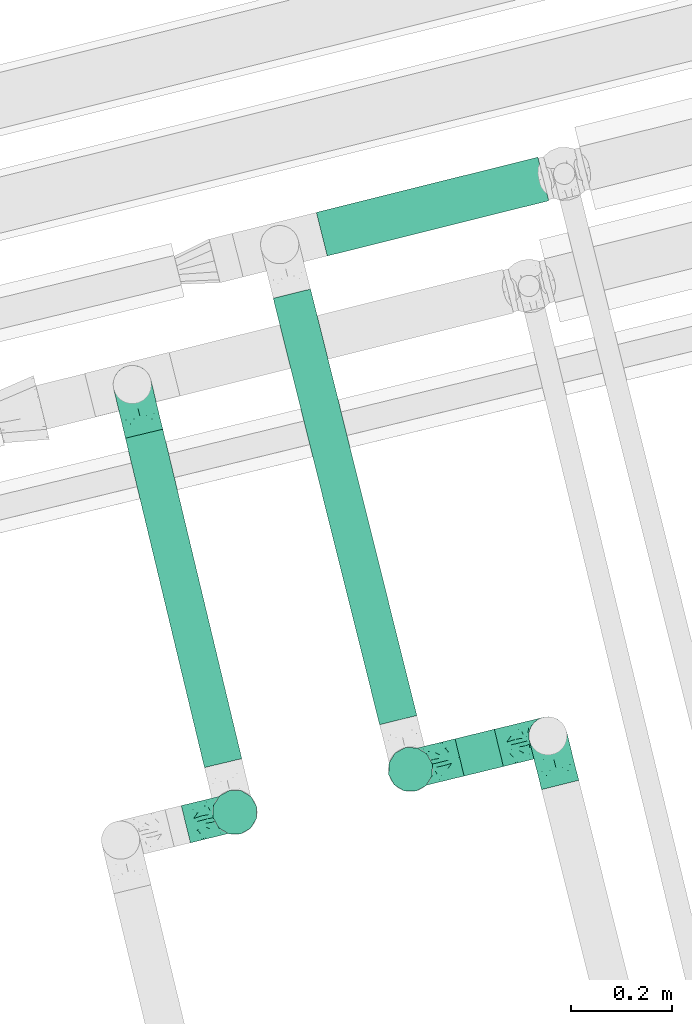
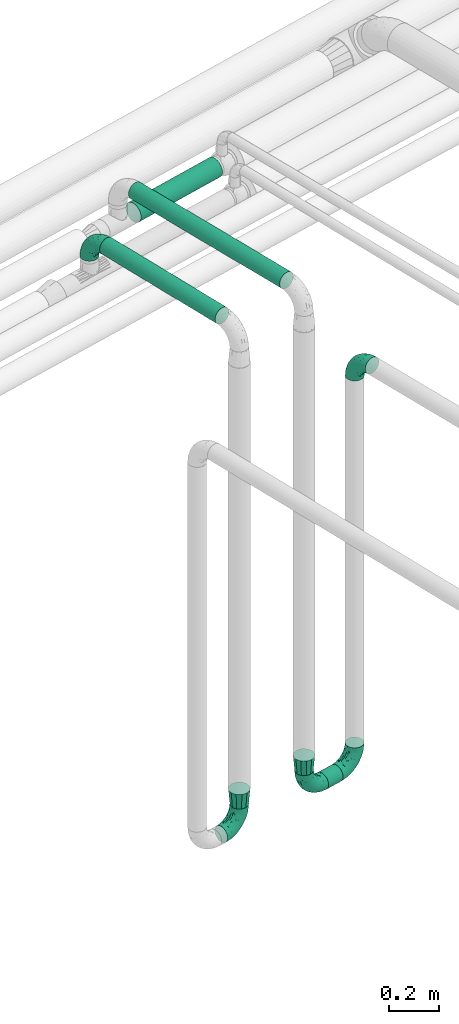
# One storey, part 52 of 93: 7 flow fittings, 4 flow segments.
"""IFC2X3 building model written with IfcOpenShell, lengths in millimetres."""

from ifc_helpers import new_model, entity, si_unit, converted_unit, derived_unit, direction, frame, origin, origin_2d_with_axis, place, context, subcontext, project, spatial, circle, extrude, faceted_brep, source, transform, mapped, material, type_object, type_shapes, element, save


model = new_model("IFC2X3")

# Units and contexts
model_context = context("Model", 3, precision=0.01, world=origin(), true_north=direction((6.12303176911189e-17, 1.0)))
body_context = subcontext(model_context, "Body", "Model", "MODEL_VIEW")
ifc_project = project(units=[si_unit("LENGTHUNIT", "METRE", prefix="MILLI"), si_unit("AREAUNIT", "SQUARE_METRE"), si_unit("VOLUMEUNIT", "CUBIC_METRE"), converted_unit("PLANEANGLEUNIT", "DEGREE", entity("IfcRatioMeasure", 0.0174532925199433), si_unit("PLANEANGLEUNIT", "RADIAN"), dimensions=[0, 0, 0, 0, 0, 0, 0]), si_unit("MASSUNIT", "GRAM", prefix="KILO"), derived_unit("MASSDENSITYUNIT", [(si_unit("MASSUNIT", "GRAM", prefix="KILO"), 1), (si_unit("LENGTHUNIT", "METRE"), -3)]), derived_unit("MOMENTOFINERTIAUNIT", [(si_unit("LENGTHUNIT", "METRE"), 4)]), si_unit("TIMEUNIT", "SECOND"), si_unit("FREQUENCYUNIT", "HERTZ"), si_unit("THERMODYNAMICTEMPERATUREUNIT", "DEGREE_CELSIUS"), derived_unit("THERMALTRANSMITTANCEUNIT", [(si_unit("MASSUNIT", "GRAM", prefix="KILO"), 1), (si_unit("THERMODYNAMICTEMPERATUREUNIT", "KELVIN"), -1), (si_unit("TIMEUNIT", "SECOND"), -3)]), derived_unit("VOLUMETRICFLOWRATEUNIT", [(si_unit("LENGTHUNIT", "METRE"), 3), (si_unit("TIMEUNIT", "SECOND"), -1)]), derived_unit("MASSFLOWRATEUNIT", [(si_unit("MASSUNIT", "GRAM", prefix="KILO"), 1), (si_unit("TIMEUNIT", "SECOND"), -1)]), derived_unit("ROTATIONALFREQUENCYUNIT", [(si_unit("TIMEUNIT", "SECOND"), -1)]), si_unit("ELECTRICCURRENTUNIT", "AMPERE"), si_unit("ELECTRICVOLTAGEUNIT", "VOLT"), si_unit("POWERUNIT", "WATT"), si_unit("FORCEUNIT", "NEWTON", prefix="KILO"), si_unit("ILLUMINANCEUNIT", "LUX"), si_unit("LUMINOUSFLUXUNIT", "LUMEN"), si_unit("LUMINOUSINTENSITYUNIT", "CANDELA"), derived_unit("USERDEFINED", [(si_unit("MASSUNIT", "GRAM", prefix="KILO"), -1), (si_unit("LENGTHUNIT", "METRE"), -2), (si_unit("TIMEUNIT", "SECOND"), 3), (si_unit("LUMINOUSFLUXUNIT", "LUMEN"), 1)]), derived_unit("LINEARVELOCITYUNIT", [(si_unit("LENGTHUNIT", "METRE"), 1), (si_unit("TIMEUNIT", "SECOND"), -1)]), si_unit("PRESSUREUNIT", "PASCAL"), derived_unit("USERDEFINED", [(si_unit("LENGTHUNIT", "METRE"), -2), (si_unit("MASSUNIT", "GRAM", prefix="KILO"), 1), (si_unit("TIMEUNIT", "SECOND"), -2)]), derived_unit("LINEARFORCEUNIT", [(si_unit("MASSUNIT", "GRAM", prefix="KILO"), 1), (si_unit("LENGTHUNIT", "METRE"), 1), (si_unit("TIMEUNIT", "SECOND"), -2), (si_unit("LENGTHUNIT", "METRE"), -1)]), derived_unit("PLANARFORCEUNIT", [(si_unit("MASSUNIT", "GRAM", prefix="KILO"), 1), (si_unit("LENGTHUNIT", "METRE"), 1), (si_unit("TIMEUNIT", "SECOND"), -2), (si_unit("LENGTHUNIT", "METRE"), -2)])], contexts=[model_context])

# Site, building, storey
site_placement = place(None, origin())
site = spatial("IfcSite", under=ifc_project, at=site_placement, CompositionType="ELEMENT")
building_placement = place(site_placement, origin())
building = spatial("IfcBuilding", under=site, at=building_placement, CompositionType="ELEMENT")
storey_placement = place(building_placement, frame((0.0, 0.0, -4200.0)))
storey = spatial("IfcBuildingStorey", under=building, at=storey_placement, CompositionType="ELEMENT", Elevation=-4200.0)

# Flow segments
pipe_segment_type = type_object("IfcPipeSegmentType", PredefinedType="NOTDEFINED")
flow_segment_1_placement = place(storey_placement, frame((-11643.94, 11578.44, 2660.4)))
element("IfcFlowSegment", 1, at=flow_segment_1_placement, inside=storey, type_object=pipe_segment_type, context=body_context, shape_type="SweptSolid", body=[
    extrude(circle(Radius=38.0, at=origin_2d_with_axis()), frame((38.55, 662.55, 39.6), z_axis=(0.233250782190029, -0.972416614732461, 0.0), x_axis=(-0.972416614732461, -0.233250782190029, 2.36724192397386e-08)), (0.0, 0.0, 1.0), 670.590915200018),
])
flow_segment_2_placement = place(storey_placement, frame((-11351.29, 11663.21, 2660.4)))
element("IfcFlowSegment", 2, at=flow_segment_2_placement, inside=storey, type_object=pipe_segment_type, context=body_context, shape_type="SweptSolid", body=[
    extrude(circle(Radius=38.0, at=origin_2d_with_axis()), frame((248.96, 10.79, 39.6), z_axis=(-0.241950055468514, 0.970288704798105, 0.0), x_axis=(0.970288704798104, 0.241950055468514, 1.38775757780529e-08)), (0.0, 0.0, 1.0), 869.994640308663),
])
flow_segment_3_placement = place(storey_placement, frame((-10991.44, 11561.61, 220.4)))
element("IfcFlowSegment", 3, at=flow_segment_3_placement, inside=storey, type_object=pipe_segment_type, context=body_context, shape_type="SweptSolid", body=[
    extrude(circle(Radius=38.0, at=origin_2d_with_axis()), frame((10.59, 38.51, 39.6), z_axis=(0.97155336378743, 0.236820736662418, 0.0), x_axis=(0.236820736662418, -0.97155336378743, 0.0)), (0.0, 0.0, 1.0), 80.0000000000123),
])
flow_segment_4_placement = place(storey_placement, frame((-11265.94, 12591.21, 2454.21)))
element("IfcFlowSegment", 4, at=flow_segment_4_placement, inside=storey, type_object=pipe_segment_type, context=body_context, shape_type="SweptSolid", body=[
    extrude(circle(Radius=44.5, at=origin_2d_with_axis()), frame((12.36, 44.77, 46.1), z_axis=(0.970294477586808, 0.241926903763397, 0.0), x_axis=(-0.241926903763397, 0.970294477586808, 0.0)), (0.0, 0.0, 1.0), 451.870706498896),
])

# Flow fittings
ifc_material = material()
pipe_fitting_type_1 = type_object("IfcPipeFittingType", Name="ADSK_2", PredefinedType="NOTDEFINED", material=ifc_material)
shared_shape_1 = source(origin(), body_context, "Body", "Brep", [
    faceted_brep([(-100.0, 19.0, -32.91), (-100.0, 9.84, -36.71), (-100.0, 0.0, -38.0), (-100.0, -9.84, -36.71), (-100.0, -19.0, -32.91), (-100.0, -26.87, -26.87), (-100.0, -32.91, -19.0), (-100.0, -36.71, -9.84), (-100.0, -38.0, 0.0), (-100.0, -36.71, 9.84), (-100.0, -32.91, 19.0), (-100.0, -26.87, 26.87), (-100.0, -19.0, 32.91), (-100.0, -9.84, 36.71), (-100.0, 0.0, 38.0), (-100.0, 9.84, 36.71), (-100.0, 19.0, 32.91), (-100.0, 26.87, 26.87), (-100.0, 32.91, 19.0), (-100.0, 36.71, 9.84), (-100.0, 38.0, 0.0), (-100.0, 36.71, -9.84), (-100.0, 32.91, -19.0), (-100.0, 26.87, -26.87), (0.0, 100.0, -38.0), (-9.84, 100.0, -36.71), (-19.0, 100.0, -32.91), (-26.87, 100.0, -26.87), (-32.91, 100.0, -19.0), (-36.71, 100.0, -9.84), (-38.0, 100.0, 0.0), (-36.71, 100.0, 9.84), (-32.91, 100.0, 19.0), (-26.87, 100.0, 26.87), (-19.0, 100.0, 32.91), (-9.84, 100.0, 36.71), (0.0, 100.0, 38.0), (9.84, 100.0, 36.71), (19.0, 100.0, 32.91), (26.87, 100.0, 26.87), (32.91, 100.0, 19.0), (36.71, 100.0, 9.84), (38.0, 100.0, 0.0), (36.71, 100.0, -9.84), (32.91, 100.0, -19.0), (26.87, 100.0, -26.87), (19.0, 100.0, -32.91), (9.84, 100.0, -36.71), (-40.69, 71.44, 16.62), (-81.22, -35.53, 0.0), (-67.52, -31.95, 12.5), (-8.97, -2.95, 6.59), (-11.71, -2.76, 13.62), (-24.68, -14.61, 8.04), (-64.28, -33.3, 0.0), (-83.72, 23.85, 30.89), (-76.19, 33.07, 24.6), (-74.13, -28.58, 21.76), (13.92, 43.47, 26.56), (5.03, 42.28, 32.41), (2.17, 22.78, 25.61), (20.11, 65.77, 28.71), (-65.77, -20.11, 28.71), (-74.23, -13.22, 34.41), (-44.44, -24.14, 12.16), (-47.64, -26.4, 0.0), (-31.0, -19.51, 0.0), (-54.86, 48.59, 21.12), (-81.56, 37.18, 15.86), (-42.28, -5.03, 32.41), (-52.67, 2.67, 37.1), (-14.76, 85.65, 35.5), (-6.46, 75.04, 37.87), (-58.38, 40.19, 26.6), (-15.88, 37.27, 37.68), (-29.21, 13.39, 36.1), (-10.53, 30.95, 35.7), (-77.78, -4.12, 37.45), (-2.67, 52.67, 37.1), (-76.41, 41.64, 8.45), (-71.15, 7.29, 37.89), (-32.26, 79.13, 24.41), (-44.28, 53.84, 26.08), (-25.18, 76.9, 31.2), (19.6, 43.38, 19.97), (6.25, 18.29, 16.9), (19.92, 34.73, 10.46), (-60.8, 50.97, 7.63), (-76.27, 42.72, 0.0), (-77.34, 15.98, 35.72), (-15.11, 15.11, 32.27), (-22.78, -2.17, 25.61), (28.58, 74.13, 21.76), (31.95, 67.52, 12.5), (-51.02, 30.39, 34.96), (-54.69, 20.06, 37.12), (26.4, 47.64, 0.0), (-51.15, 12.85, 38.0), (-32.84, 22.95, 37.94), (4.12, 77.78, 37.45), (-43.38, -19.6, 19.97), (35.53, 81.22, 0.0), (13.22, 74.23, 34.41), (-39.82, 82.33, 7.34), (-42.72, 76.27, 0.0), (-33.83, 52.47, 33.18), (-48.09, 40.81, 31.48), (-56.16, 56.16, 0.0), (-48.2, 64.18, 8.55), (-18.69, 66.93, 35.98), (-49.98, 57.58, 16.12), (-62.54, 46.99, 14.59), (-43.26, -12.84, 27.42), (-17.52, 48.72, 37.89), (-64.19, 29.4, 31.78), (-27.05, 50.9, 36.03), (-36.14, 36.14, 36.75), (-23.99, -8.71, 19.44), (6.3, 13.34, 7.98), (19.51, 31.0, 0.0), (-7.64, 6.3, 21.15), (-16.71, -8.55, 0.0), (33.3, 64.28, 0.0), (-2.42, 2.42, 0.0), (8.55, 16.71, 0.0), (-85.65, 14.76, -35.5), (-23.85, 83.72, -30.89), (-33.07, 76.19, -24.6), (-75.04, 6.46, -37.87), (-37.27, 15.88, -37.68), (-13.39, 29.21, -36.1), (-30.95, 10.53, -35.7), (-79.13, 32.26, -24.41), (-76.9, 25.18, -31.2), (6.3, 13.34, -7.98), (-11.71, -2.76, -13.62), (6.25, 18.29, -16.9), (-82.33, 39.82, -7.34), (-66.93, 18.69, -35.98), (-48.72, 17.52, -37.89), (-64.18, 48.2, -8.55), (31.95, 67.52, -12.5), (28.58, 74.13, -21.76), (-52.47, 33.83, -33.18), (4.12, 77.78, -37.45), (-7.29, 71.15, -37.89), (-15.98, 77.34, -35.72), (-67.52, -31.95, -12.5), (-30.39, 51.02, -34.96), (-20.06, 54.69, -37.12), (-48.59, 54.86, -21.12), (-37.18, 81.56, -15.86), (-74.13, -28.58, -21.76), (-29.4, 64.19, -31.78), (-40.81, 48.09, -31.48), (-40.19, 58.38, -26.6), (-65.77, -20.11, -28.71), (-74.23, -13.22, -34.41), (-39.81, -22.62, -10.22), (-77.78, -4.12, -37.45), (-43.38, -19.6, -19.97), (-12.85, 51.15, -38.0), (-22.95, 32.84, -37.94), (-71.44, 40.69, -16.62), (19.6, 43.38, -19.97), (20.11, 65.77, -28.71), (-52.67, 2.67, -37.1), (-53.84, 44.28, -26.08), (-41.64, 76.41, -8.45), (-23.99, -8.71, -19.44), (-43.47, -13.92, -26.56), (-22.78, -2.17, -25.61), (-20.59, -12.11, -6.83), (13.22, 74.23, -34.41), (5.03, 42.28, -32.41), (-2.67, 52.67, -37.1), (19.92, 34.73, -10.46), (-42.28, -5.03, -32.41), (12.84, 43.26, -27.42), (-50.97, 60.8, -7.63), (-57.58, 49.98, -16.12), (-46.99, 62.54, -14.59), (-50.9, 27.05, -36.03), (-36.14, 36.14, -36.75), (-15.11, 15.11, -32.27), (2.17, 22.78, -25.61), (-7.64, 6.3, -21.15), (-6.28, -0.33, -7.3)], [[[0, 1, 2, 3, 4, 5, 6, 7, 8, 9, 10, 11, 12, 13, 14, 15, 16, 17, 18, 19, 20, 21, 22, 23]], [[24, 25, 26, 27, 28, 29, 30, 31, 32, 33, 34, 35, 36, 37, 38, 39, 40, 41, 42, 43, 44, 45, 46, 47]], [[32, 31, 48]], [[49, 50, 9]], [[51, 52, 53]], [[9, 50, 10]], [[54, 50, 49]], [[17, 55, 56]], [[11, 10, 57]], [[58, 59, 60]], [[61, 39, 38]], [[62, 12, 11]], [[62, 63, 12]], [[64, 65, 66]], [[56, 67, 68]], [[63, 69, 70]], [[35, 71, 72]], [[67, 56, 73]], [[74, 75, 76]], [[16, 55, 17]], [[13, 77, 14]], [[76, 78, 74]], [[68, 79, 19]], [[18, 17, 56]], [[14, 77, 80]], [[20, 19, 79]], [[81, 82, 83]], [[84, 85, 86]], [[87, 88, 79]], [[18, 68, 19]], [[15, 89, 16]], [[14, 80, 15]], [[85, 84, 60]], [[90, 69, 91]], [[92, 84, 93]], [[94, 89, 95]], [[86, 96, 93]], [[83, 71, 34]], [[95, 97, 98]], [[37, 36, 99]], [[40, 39, 92]], [[40, 93, 41]], [[66, 53, 64]], [[92, 93, 40]], [[57, 100, 62]], [[93, 101, 41]], [[93, 84, 86]], [[61, 102, 59]], [[34, 33, 83]], [[103, 48, 31]], [[50, 57, 10]], [[104, 103, 30]], [[94, 105, 106]], [[104, 107, 108]], [[12, 63, 13]], [[83, 109, 71]], [[83, 105, 109]], [[33, 81, 83]], [[67, 110, 111]], [[108, 103, 104]], [[112, 69, 62]], [[34, 71, 35]], [[36, 35, 72]], [[109, 113, 72]], [[102, 38, 37]], [[102, 61, 38]], [[114, 106, 73]], [[89, 15, 80]], [[33, 32, 81]], [[115, 105, 116]], [[109, 115, 113]], [[99, 72, 78]], [[111, 87, 79]], [[108, 87, 110]], [[69, 63, 62]], [[77, 63, 70]], [[100, 117, 112]], [[69, 90, 75]], [[99, 102, 37]], [[78, 76, 59]], [[78, 59, 102]], [[59, 90, 60]], [[100, 57, 50]], [[62, 11, 57]], [[39, 61, 92]], [[84, 92, 61]], [[95, 89, 80]], [[55, 89, 114]], [[83, 82, 105]], [[94, 106, 114]], [[98, 113, 116]], [[78, 72, 113]], [[98, 116, 95]], [[98, 70, 75]], [[32, 48, 81]], [[82, 81, 48]], [[91, 112, 117]], [[60, 84, 58]], [[113, 115, 116]], [[118, 119, 86]], [[90, 91, 60]], [[91, 117, 120]], [[72, 99, 36]], [[102, 99, 78]], [[63, 77, 13]], [[80, 77, 70]], [[95, 80, 97]], [[94, 95, 116]], [[56, 68, 18]], [[79, 68, 111]], [[110, 87, 111]], [[79, 88, 20]], [[108, 107, 87]], [[88, 87, 107]], [[120, 60, 91]], [[66, 121, 53]], [[118, 86, 85]], [[122, 93, 96]], [[52, 118, 85]], [[118, 123, 124, 119]], [[48, 103, 108]], [[30, 103, 31]], [[89, 55, 16]], [[56, 55, 114]], [[80, 70, 97]], [[70, 98, 97]], [[105, 94, 116]], [[89, 94, 114]], [[105, 82, 106]], [[73, 106, 82]], [[67, 73, 82]], [[114, 73, 56]], [[110, 82, 48]], [[67, 111, 68]], [[82, 110, 67]], [[108, 110, 48]], [[69, 75, 70]], [[76, 75, 90]], [[59, 76, 90]], [[78, 113, 74]], [[113, 98, 74]], [[75, 74, 98]], [[9, 8, 49]], [[101, 93, 122]], [[101, 42, 41]], [[72, 71, 109]], [[50, 54, 65]], [[117, 53, 52]], [[109, 105, 115]], [[100, 112, 62]], [[91, 69, 112]], [[123, 51, 121]], [[120, 52, 85]], [[52, 120, 117]], [[60, 120, 85]], [[51, 118, 52]], [[100, 64, 117]], [[50, 64, 100]], [[121, 51, 53]], [[118, 51, 123]], [[84, 61, 58]], [[59, 58, 61]], [[86, 119, 96]], [[65, 64, 50]], [[117, 64, 53]], [[125, 1, 0]], [[27, 126, 127]], [[2, 1, 128]], [[129, 130, 131]], [[132, 133, 23]], [[134, 135, 136]], [[88, 137, 20]], [[138, 139, 128]], [[88, 107, 140]], [[141, 142, 44]], [[138, 133, 143]], [[24, 144, 145]], [[146, 25, 145]], [[125, 133, 138]], [[6, 147, 7]], [[148, 146, 149]], [[147, 49, 7]], [[127, 150, 151]], [[147, 6, 152]], [[153, 154, 155]], [[156, 4, 157]], [[140, 137, 88]], [[24, 145, 25]], [[43, 42, 101]], [[65, 147, 158]], [[148, 143, 154]], [[159, 3, 2]], [[147, 152, 160]], [[149, 161, 162]], [[156, 5, 4]], [[137, 163, 21]], [[142, 164, 165]], [[131, 166, 129]], [[28, 151, 29]], [[167, 133, 132]], [[168, 30, 29]], [[169, 170, 171]], [[127, 28, 27]], [[150, 127, 155]], [[135, 172, 158]], [[26, 25, 146]], [[1, 125, 128]], [[22, 21, 163]], [[126, 27, 26]], [[151, 168, 29]], [[24, 47, 144]], [[45, 165, 46]], [[0, 23, 133]], [[173, 174, 175]], [[119, 134, 176]], [[142, 45, 44]], [[173, 46, 165]], [[141, 44, 43]], [[46, 173, 47]], [[141, 101, 122]], [[156, 157, 177]], [[157, 4, 3]], [[101, 141, 43]], [[178, 174, 165]], [[169, 160, 170]], [[6, 5, 152]], [[170, 177, 171]], [[158, 147, 160]], [[104, 168, 179]], [[141, 96, 176]], [[150, 180, 181]], [[23, 22, 132]], [[182, 143, 183]], [[138, 182, 139]], [[159, 128, 166]], [[181, 179, 168]], [[140, 179, 180]], [[159, 157, 3]], [[166, 131, 177]], [[166, 177, 157]], [[177, 184, 171]], [[174, 173, 165]], [[144, 173, 175]], [[178, 164, 185]], [[174, 184, 130]], [[5, 156, 152]], [[160, 152, 156]], [[164, 142, 141]], [[165, 45, 142]], [[149, 146, 145]], [[126, 146, 153]], [[133, 167, 143]], [[148, 154, 153]], [[162, 139, 183]], [[166, 128, 139]], [[162, 183, 149]], [[162, 175, 130]], [[22, 163, 132]], [[167, 132, 163]], [[174, 185, 184]], [[136, 176, 134]], [[185, 136, 186]], [[158, 172, 66]], [[136, 185, 164]], [[171, 184, 185]], [[128, 159, 2]], [[157, 159, 166]], [[173, 144, 47]], [[145, 144, 175]], [[149, 145, 161]], [[148, 149, 183]], [[127, 151, 28]], [[168, 151, 181]], [[180, 179, 181]], [[168, 104, 30]], [[140, 107, 179]], [[104, 179, 107]], [[176, 136, 164]], [[135, 169, 186]], [[141, 176, 164]], [[134, 119, 124, 123]], [[158, 66, 65]], [[187, 172, 135]], [[163, 137, 140]], [[20, 137, 21]], [[146, 126, 26]], [[127, 126, 153]], [[145, 175, 161]], [[175, 162, 161]], [[143, 148, 183]], [[146, 148, 153]], [[143, 167, 154]], [[155, 154, 167]], [[150, 155, 167]], [[153, 155, 127]], [[180, 167, 163]], [[150, 181, 151]], [[167, 180, 150]], [[140, 180, 163]], [[174, 130, 175]], [[131, 130, 184]], [[177, 131, 184]], [[166, 139, 129]], [[139, 162, 129]], [[130, 129, 162]], [[49, 147, 54]], [[49, 8, 7]], [[133, 125, 0]], [[128, 125, 138]], [[158, 160, 169]], [[65, 54, 147]], [[187, 135, 134]], [[187, 121, 172]], [[134, 123, 187]], [[139, 182, 183]], [[121, 187, 123]], [[121, 66, 172]], [[138, 143, 182]], [[160, 156, 170]], [[177, 170, 156]], [[186, 169, 171]], [[158, 169, 135]], [[185, 186, 171]], [[135, 186, 136]], [[164, 178, 165]], [[185, 174, 178]], [[96, 141, 122]], [[96, 119, 176]]]),
])
type_shapes(pipe_fitting_type_1, [shared_shape_1])
for number, where, z_axis, x_axis, name in (
    (5, (-11425.65, 11491.65, 270.0), (-0.23682073666241, 0.971553363787432, 0.0), (0.0, 0.0, -1.0), "ADSK_2"),
    (6, (-11078.01, 11576.44, 260.0), (0.236820736662414, -0.971553363787431, 0.0), (0.0, 0.0, -1.0), "ADSK_2"),
    (7, (-10805.97, 11642.75, 260.0), (0.236820736662404, -0.971553363787433, 0.0), (0.971553363787433, 0.236820736662404, 0.0), "ADSK_2"),
    (8, (-10805.97, 11642.75, 2250.0), (0.970245218594306, 0.242124380835321, 0.0), (0.0, 0.0, 1.0), "ADSK_2"),
):
    element("IfcFlowFitting", number, at=place(storey_placement, frame(where, z_axis=z_axis, x_axis=x_axis)), inside=storey, type_object=pipe_fitting_type_1, material=ifc_material, Name=name, ObjectType="ADSK_2", context=body_context, shape_type="MappedRepresentation", body=[
        mapped(shared_shape_1, transform((0.0, 0.0, 0.0), scale=1.0)),
    ])
pipe_fitting_type_2 = type_object("IfcPipeFittingType", Name="ADSK_2", PredefinedType="NOTDEFINED", material=ifc_material)
shared_shape_2 = source(origin(), body_context, "Body", "Brep", [
    faceted_brep([(75.0, -44.5, 0.0), (75.0, -41.54, -11.05), (75.0, -38.54, -22.25), (75.0, -30.39, -30.39), (75.0, -22.25, -38.54), (75.0, -11.13, -41.52), (75.0, 0.0, -44.5), (75.0, 11.12, -41.52), (75.0, 22.25, -38.54), (75.0, 30.39, -30.39), (75.0, 38.54, -22.25), (75.0, 41.54, -11.05), (75.0, 44.5, 0.0), (75.0, 41.54, 11.05), (75.0, 38.54, 22.25), (75.0, 30.39, 30.39), (75.0, 22.25, 38.54), (75.0, 11.12, 41.52), (75.0, 0.0, 44.5), (75.0, -11.13, 41.52), (75.0, -22.25, 38.54), (75.0, -30.39, 30.39), (75.0, -38.54, 22.25), (75.0, -41.54, 11.05), (0.0, -32.91, -19.0), (0.0, -35.45, -9.5), (0.0, -38.0, 0.0), (0.0, -35.45, 9.5), (0.0, -32.91, 19.0), (0.0, -25.95, 25.95), (0.0, -19.0, 32.91), (0.0, -9.5, 35.45), (0.0, 0.0, 38.0), (0.0, 9.5, 35.45), (0.0, 19.0, 32.91), (0.0, 25.95, 25.95), (0.0, 32.91, 19.0), (0.0, 35.45, 9.5), (0.0, 38.0, 0.0), (0.0, 35.45, -9.5), (0.0, 32.91, -19.0), (0.0, 25.95, -25.95), (0.0, 19.0, -32.91), (0.0, 9.5, -35.45), (0.0, 0.0, -38.0), (0.0, -9.5, -35.45), (0.0, -19.0, -32.91), (0.0, -25.95, -25.95)], [[[0, 1, 2, 3, 4, 5, 6, 7, 8, 9, 10, 11, 12, 13, 14, 15, 16, 17, 18, 19, 20, 21, 22, 23]], [[24, 25, 26, 27, 28, 29, 30, 31, 32, 33, 34, 35, 36, 37, 38, 39, 40, 41, 42, 43, 44, 45, 46, 47]], [[24, 47, 46, 4, 3, 2]], [[42, 8, 7, 6, 44, 43]], [[10, 40, 39, 38, 12, 11]], [[44, 6, 5, 4, 46, 45]], [[2, 1, 0, 26, 25, 24]], [[9, 8, 42, 41, 40, 10]], [[36, 35, 34, 16, 15, 14]], [[30, 20, 19, 18, 32, 31]], [[22, 28, 27, 26, 0, 23]], [[32, 18, 17, 16, 34, 33]], [[14, 13, 12, 38, 37, 36]], [[21, 20, 30, 29, 28, 22]]]),
])
type_shapes(pipe_fitting_type_2, [shared_shape_2])
for number, where, z_axis, x_axis, name in (
    (9, (-11425.65, 11491.65, 370.0), (-0.23682073666241, 0.971553363787432, 0.0), (0.0, 0.0, 1.0), "ADSK_2"),
    (10, (-11078.01, 11576.44, 360.0), (0.236820736662414, -0.971553363787431, 0.0), (0.0, 0.0, 1.0), "ADSK_2"),
):
    element("IfcFlowFitting", number, at=place(storey_placement, frame(where, z_axis=z_axis, x_axis=x_axis)), inside=storey, type_object=pipe_fitting_type_2, material=ifc_material, Name=name, ObjectType="ADSK_2", context=body_context, shape_type="MappedRepresentation", body=[
        mapped(shared_shape_2, transform((0.0, 0.0, 0.0), scale=1.0)),
    ])
pipe_fitting_type_3 = type_object("IfcPipeFittingType", Name="ADSK_2", PredefinedType="NOTDEFINED", material=ifc_material)
shared_shape_3 = source(origin(), body_context, "Body", "Brep", [
    faceted_brep([(-100.0, 19.0, -32.91), (-100.0, 9.84, -36.71), (-100.0, 0.0, -38.0), (-100.0, -9.84, -36.71), (-100.0, -19.0, -32.91), (-100.0, -26.87, -26.87), (-100.0, -32.91, -19.0), (-100.0, -36.71, -9.84), (-100.0, -38.0, 0.0), (-100.0, -36.71, 9.84), (-100.0, -32.91, 19.0), (-100.0, -26.87, 26.87), (-100.0, -19.0, 32.91), (-100.0, -9.84, 36.71), (-100.0, 0.0, 38.0), (-100.0, 9.84, 36.71), (-100.0, 19.0, 32.91), (-100.0, 26.87, 26.87), (-100.0, 32.91, 19.0), (-100.0, 36.71, 9.84), (-100.0, 38.0, 0.0), (-100.0, 36.71, -9.84), (-100.0, 32.91, -19.0), (-100.0, 26.87, -26.87), (-9.84, 100.0, -36.71), (-19.0, 100.0, -32.91), (-26.87, 100.0, -26.87), (-32.91, 100.0, -19.0), (-36.71, 100.0, -9.84), (-38.0, 100.0, 0.0), (-36.71, 100.0, 9.84), (-32.91, 100.0, 19.0), (-26.87, 100.0, 26.87), (-19.0, 100.0, 32.91), (-9.84, 100.0, 36.71), (0.0, 100.0, 38.0), (9.83, 100.0, 36.71), (19.0, 100.0, 32.91), (26.87, 100.0, 26.87), (32.91, 100.0, 19.0), (36.7, 100.0, 9.84), (38.0, 100.0, 0.0), (36.7, 100.0, -9.84), (32.91, 100.0, -19.0), (26.87, 100.0, -26.87), (19.0, 100.0, -32.91), (9.83, 100.0, -36.71), (0.0, 100.0, -38.0), (-40.69, 71.44, 16.62), (-81.22, -35.53, 0.0), (-67.52, -31.95, 12.5), (-8.97, -2.95, 6.59), (-11.71, -2.76, 13.62), (-24.68, -14.61, 8.04), (-64.28, -33.3, 0.0), (-83.72, 23.85, 30.89), (-76.19, 33.07, 24.6), (-74.13, -28.58, 21.76), (13.92, 43.47, 26.56), (5.03, 42.28, 32.41), (2.17, 22.78, 25.61), (20.11, 65.77, 28.71), (-65.77, -20.11, 28.71), (-74.23, -13.22, 34.41), (-44.44, -24.14, 12.16), (-47.64, -26.4, 0.0), (-31.0, -19.51, 0.0), (-54.86, 48.59, 21.12), (-81.56, 37.18, 15.86), (-42.28, -5.03, 32.41), (-52.67, 2.67, 37.1), (-14.76, 85.65, 35.5), (-6.46, 75.04, 37.87), (-58.38, 40.19, 26.6), (-15.88, 37.27, 37.68), (-29.21, 13.39, 36.1), (-10.53, 30.95, 35.7), (-77.78, -4.12, 37.45), (-2.67, 52.67, 37.1), (-76.41, 41.64, 8.45), (-71.15, 7.29, 37.89), (-32.26, 79.13, 24.41), (-44.28, 53.84, 26.08), (-25.18, 76.9, 31.2), (19.6, 43.38, 19.97), (6.25, 18.3, 16.9), (19.92, 34.73, 10.46), (-60.8, 50.97, 7.63), (-76.27, 42.72, 0.0), (-77.34, 15.98, 35.72), (-15.11, 15.11, 32.27), (-22.78, -2.17, 25.61), (28.58, 74.13, 21.76), (31.95, 67.52, 12.5), (-51.02, 30.39, 34.96), (-54.69, 20.06, 37.12), (26.4, 47.64, 0.0), (-51.15, 12.85, 38.0), (-32.84, 22.95, 37.94), (4.12, 77.78, 37.45), (-43.38, -19.6, 19.97), (35.53, 81.22, 0.0), (13.22, 74.23, 34.41), (-39.82, 82.33, 7.34), (-42.72, 76.27, 0.0), (-33.83, 52.47, 33.18), (-48.09, 40.81, 31.48), (-56.16, 56.16, 0.0), (-48.2, 64.18, 8.55), (-18.69, 66.93, 35.98), (-49.98, 57.58, 16.12), (-62.54, 46.99, 14.59), (-43.26, -12.84, 27.42), (-17.52, 48.72, 37.89), (-64.19, 29.4, 31.78), (-27.05, 50.9, 36.03), (-36.14, 36.14, 36.75), (-23.99, -8.71, 19.44), (6.3, 13.34, 7.98), (19.51, 31.0, 0.0), (-7.64, 6.3, 21.15), (-16.71, -8.55, 0.0), (33.3, 64.28, 0.0), (-2.42, 2.42, 0.0), (8.55, 16.71, 0.0), (-85.65, 14.76, -35.5), (-23.85, 83.72, -30.89), (-33.07, 76.19, -24.6), (-75.04, 6.46, -37.87), (-37.27, 15.88, -37.68), (-13.39, 29.21, -36.1), (-30.95, 10.53, -35.7), (-79.13, 32.26, -24.41), (-76.9, 25.18, -31.2), (6.3, 13.34, -7.98), (-11.71, -2.76, -13.62), (6.25, 18.3, -16.9), (-82.33, 39.82, -7.34), (-66.93, 18.69, -35.98), (-48.72, 17.52, -37.89), (-64.18, 48.2, -8.55), (31.95, 67.52, -12.5), (28.58, 74.13, -21.76), (-52.47, 33.83, -33.18), (4.12, 77.78, -37.45), (-7.29, 71.15, -37.89), (-15.98, 77.34, -35.72), (-67.52, -31.95, -12.5), (-30.39, 51.02, -34.96), (-20.06, 54.69, -37.12), (-48.59, 54.86, -21.12), (-37.18, 81.56, -15.86), (-74.13, -28.58, -21.76), (-29.4, 64.19, -31.78), (-40.81, 48.09, -31.48), (-40.19, 58.38, -26.6), (-65.77, -20.11, -28.71), (-74.23, -13.22, -34.41), (-39.81, -22.62, -10.22), (-77.78, -4.12, -37.45), (-43.38, -19.6, -19.97), (-12.85, 51.15, -38.0), (-22.95, 32.84, -37.94), (-71.44, 40.69, -16.62), (19.6, 43.38, -19.97), (20.11, 65.77, -28.71), (-52.67, 2.67, -37.1), (-53.84, 44.28, -26.08), (-41.64, 76.41, -8.45), (-23.99, -8.71, -19.44), (-43.47, -13.92, -26.56), (-22.78, -2.17, -25.61), (-20.59, -12.11, -6.83), (13.22, 74.23, -34.41), (5.03, 42.28, -32.41), (-2.67, 52.67, -37.1), (19.92, 34.73, -10.46), (-42.28, -5.03, -32.41), (12.84, 43.26, -27.42), (-50.97, 60.8, -7.63), (-57.58, 49.98, -16.12), (-46.99, 62.54, -14.59), (-50.9, 27.05, -36.03), (-15.11, 15.11, -32.27), (2.17, 22.78, -25.61), (-36.14, 36.14, -36.75), (-7.64, 6.3, -21.15), (-6.28, -0.33, -7.3)], [[[0, 1, 2, 3, 4, 5, 6, 7, 8, 9, 10, 11, 12, 13, 14, 15, 16, 17, 18, 19, 20, 21, 22, 23]], [[24, 25, 26, 27, 28, 29, 30, 31, 32, 33, 34, 35, 36, 37, 38, 39, 40, 41, 42, 43, 44, 45, 46, 47]], [[31, 30, 48]], [[49, 50, 9]], [[51, 52, 53]], [[9, 50, 10]], [[54, 50, 49]], [[17, 55, 56]], [[11, 10, 57]], [[58, 59, 60]], [[61, 38, 37]], [[62, 12, 11]], [[62, 63, 12]], [[64, 65, 66]], [[56, 67, 68]], [[63, 69, 70]], [[34, 71, 72]], [[67, 56, 73]], [[74, 75, 76]], [[16, 55, 17]], [[13, 77, 14]], [[76, 78, 74]], [[68, 79, 19]], [[18, 17, 56]], [[14, 77, 80]], [[20, 19, 79]], [[81, 82, 83]], [[84, 85, 86]], [[87, 88, 79]], [[18, 68, 19]], [[15, 89, 16]], [[14, 80, 15]], [[85, 84, 60]], [[90, 69, 91]], [[92, 84, 93]], [[94, 89, 95]], [[86, 96, 93]], [[83, 71, 33]], [[95, 97, 98]], [[36, 35, 99]], [[39, 38, 92]], [[39, 93, 40]], [[66, 53, 64]], [[92, 93, 39]], [[57, 100, 62]], [[93, 101, 40]], [[93, 84, 86]], [[61, 102, 59]], [[33, 32, 83]], [[103, 48, 30]], [[50, 57, 10]], [[104, 103, 29]], [[94, 105, 106]], [[104, 107, 108]], [[12, 63, 13]], [[83, 109, 71]], [[83, 105, 109]], [[32, 81, 83]], [[67, 110, 111]], [[108, 103, 104]], [[112, 69, 62]], [[33, 71, 34]], [[35, 34, 72]], [[109, 113, 72]], [[102, 37, 36]], [[102, 61, 37]], [[114, 106, 73]], [[89, 15, 80]], [[32, 31, 81]], [[115, 105, 116]], [[109, 115, 113]], [[99, 72, 78]], [[111, 87, 79]], [[108, 87, 110]], [[69, 63, 62]], [[77, 63, 70]], [[100, 117, 112]], [[69, 90, 75]], [[99, 102, 36]], [[78, 76, 59]], [[78, 59, 102]], [[59, 90, 60]], [[100, 57, 50]], [[62, 11, 57]], [[38, 61, 92]], [[84, 92, 61]], [[95, 89, 80]], [[55, 89, 114]], [[83, 82, 105]], [[94, 106, 114]], [[98, 113, 116]], [[78, 72, 113]], [[98, 116, 95]], [[98, 70, 75]], [[31, 48, 81]], [[82, 81, 48]], [[91, 112, 117]], [[60, 84, 58]], [[113, 115, 116]], [[118, 119, 86]], [[90, 91, 60]], [[91, 117, 120]], [[72, 99, 35]], [[102, 99, 78]], [[63, 77, 13]], [[80, 77, 70]], [[95, 80, 97]], [[94, 95, 116]], [[56, 68, 18]], [[79, 68, 111]], [[110, 87, 111]], [[79, 88, 20]], [[108, 107, 87]], [[88, 87, 107]], [[120, 60, 91]], [[66, 121, 53]], [[118, 86, 85]], [[122, 93, 96]], [[52, 118, 85]], [[118, 123, 124, 119]], [[48, 103, 108]], [[29, 103, 30]], [[89, 55, 16]], [[56, 55, 114]], [[80, 70, 97]], [[70, 98, 97]], [[105, 94, 116]], [[89, 94, 114]], [[105, 82, 106]], [[73, 106, 82]], [[67, 73, 82]], [[114, 73, 56]], [[110, 82, 48]], [[67, 111, 68]], [[82, 110, 67]], [[108, 110, 48]], [[69, 75, 70]], [[76, 75, 90]], [[59, 76, 90]], [[78, 113, 74]], [[113, 98, 74]], [[75, 74, 98]], [[9, 8, 49]], [[101, 93, 122]], [[101, 41, 40]], [[72, 71, 109]], [[50, 54, 65]], [[117, 53, 52]], [[109, 105, 115]], [[100, 112, 62]], [[91, 69, 112]], [[123, 51, 121]], [[120, 52, 85]], [[52, 120, 117]], [[60, 120, 85]], [[51, 118, 52]], [[100, 64, 117]], [[50, 64, 100]], [[121, 51, 53]], [[118, 51, 123]], [[84, 61, 58]], [[59, 58, 61]], [[86, 119, 96]], [[65, 64, 50]], [[117, 64, 53]], [[125, 1, 0]], [[26, 126, 127]], [[2, 1, 128]], [[129, 130, 131]], [[132, 133, 23]], [[134, 135, 136]], [[88, 137, 20]], [[138, 139, 128]], [[88, 107, 140]], [[141, 142, 43]], [[138, 133, 143]], [[47, 144, 145]], [[146, 24, 145]], [[125, 133, 138]], [[6, 147, 7]], [[148, 146, 149]], [[147, 49, 7]], [[127, 150, 151]], [[147, 6, 152]], [[153, 154, 155]], [[156, 4, 157]], [[140, 137, 88]], [[47, 145, 24]], [[42, 41, 101]], [[65, 147, 158]], [[148, 143, 154]], [[159, 3, 2]], [[147, 152, 160]], [[149, 161, 162]], [[156, 5, 4]], [[137, 163, 21]], [[142, 164, 165]], [[131, 166, 129]], [[27, 151, 28]], [[167, 133, 132]], [[168, 29, 28]], [[169, 170, 171]], [[127, 27, 26]], [[150, 127, 155]], [[135, 172, 158]], [[25, 24, 146]], [[1, 125, 128]], [[22, 21, 163]], [[126, 26, 25]], [[151, 168, 28]], [[47, 46, 144]], [[44, 165, 45]], [[0, 23, 133]], [[173, 174, 175]], [[119, 134, 176]], [[142, 44, 43]], [[173, 45, 165]], [[141, 43, 42]], [[45, 173, 46]], [[141, 101, 122]], [[156, 157, 177]], [[157, 4, 3]], [[101, 141, 42]], [[178, 174, 165]], [[169, 160, 170]], [[6, 5, 152]], [[170, 177, 171]], [[158, 147, 160]], [[104, 168, 179]], [[141, 96, 176]], [[150, 180, 181]], [[23, 22, 132]], [[138, 143, 182]], [[138, 182, 139]], [[159, 128, 166]], [[181, 179, 168]], [[140, 179, 180]], [[159, 157, 3]], [[166, 131, 177]], [[166, 177, 157]], [[177, 183, 171]], [[174, 173, 165]], [[144, 173, 175]], [[178, 164, 184]], [[174, 183, 130]], [[5, 156, 152]], [[160, 152, 156]], [[164, 142, 141]], [[165, 44, 142]], [[149, 146, 145]], [[126, 146, 153]], [[133, 167, 143]], [[148, 154, 153]], [[162, 139, 185]], [[166, 128, 139]], [[162, 185, 149]], [[162, 175, 130]], [[22, 163, 132]], [[167, 132, 163]], [[174, 184, 183]], [[136, 176, 134]], [[184, 136, 186]], [[158, 172, 66]], [[136, 184, 164]], [[171, 183, 184]], [[128, 159, 2]], [[157, 159, 166]], [[173, 144, 46]], [[145, 144, 175]], [[149, 145, 161]], [[148, 149, 185]], [[127, 151, 27]], [[168, 151, 181]], [[180, 179, 181]], [[168, 104, 29]], [[140, 107, 179]], [[104, 179, 107]], [[176, 136, 164]], [[135, 169, 186]], [[141, 176, 164]], [[134, 119, 124, 123]], [[158, 66, 65]], [[187, 172, 135]], [[163, 137, 140]], [[20, 137, 21]], [[146, 126, 25]], [[127, 126, 153]], [[145, 175, 161]], [[175, 162, 161]], [[143, 148, 185]], [[146, 148, 153]], [[143, 167, 154]], [[155, 154, 167]], [[150, 155, 167]], [[153, 155, 127]], [[180, 167, 163]], [[150, 181, 151]], [[167, 180, 150]], [[140, 180, 163]], [[174, 130, 175]], [[131, 130, 183]], [[177, 131, 183]], [[166, 139, 129]], [[139, 162, 129]], [[130, 129, 162]], [[49, 147, 54]], [[49, 8, 7]], [[133, 125, 0]], [[128, 125, 138]], [[158, 160, 169]], [[65, 54, 147]], [[187, 135, 134]], [[187, 121, 172]], [[134, 123, 187]], [[143, 185, 182]], [[121, 187, 123]], [[121, 66, 172]], [[139, 182, 185]], [[160, 156, 170]], [[177, 170, 156]], [[186, 169, 171]], [[158, 169, 135]], [[184, 186, 171]], [[135, 186, 136]], [[164, 178, 165]], [[184, 174, 178]], [[96, 141, 122]], [[96, 119, 176]]]),
])
type_shapes(pipe_fitting_type_3, [shared_shape_3])
flow_fitting_placement = place(storey_placement, frame((-11628.72, 12338.23, 2700.0), z_axis=(0.972416614732462, 0.233250782190025, 0.0), x_axis=(0.0, 0.0, 1.0)))
element("IfcFlowFitting", 11, at=flow_fitting_placement, inside=storey, type_object=pipe_fitting_type_3, material=ifc_material, Name="ADSK_2", ObjectType="ADSK_2", context=body_context, shape_type="MappedRepresentation", body=[
    mapped(shared_shape_3, transform((0.0, 0.0, 0.0), scale=1.0)),
])

save(model, "model.ifc")
